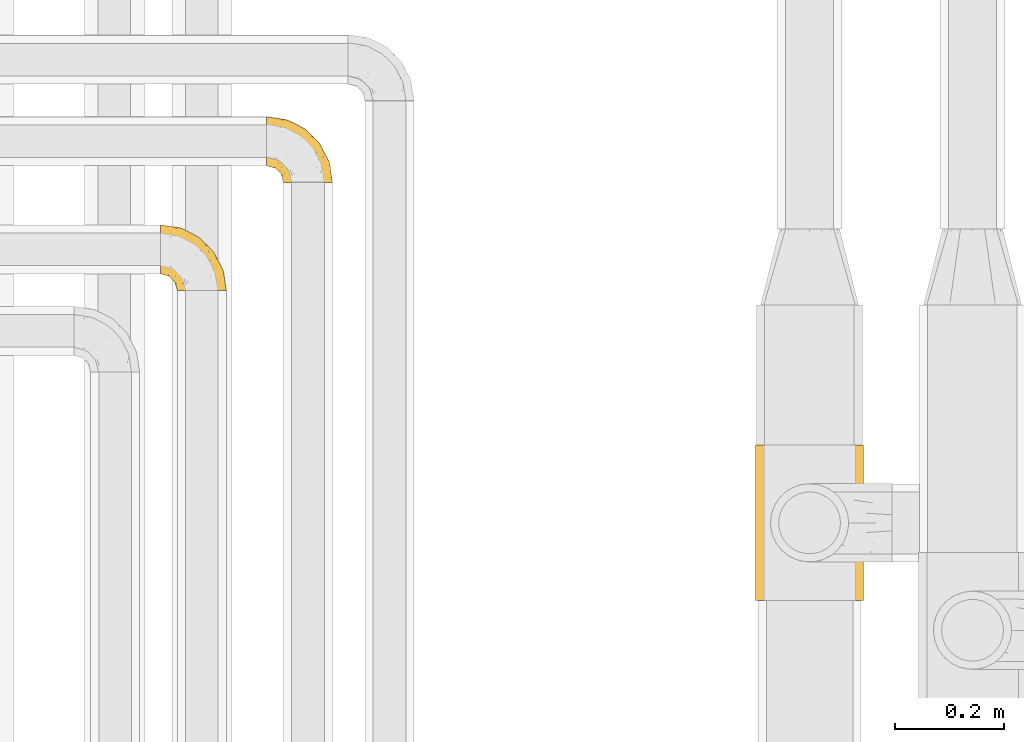
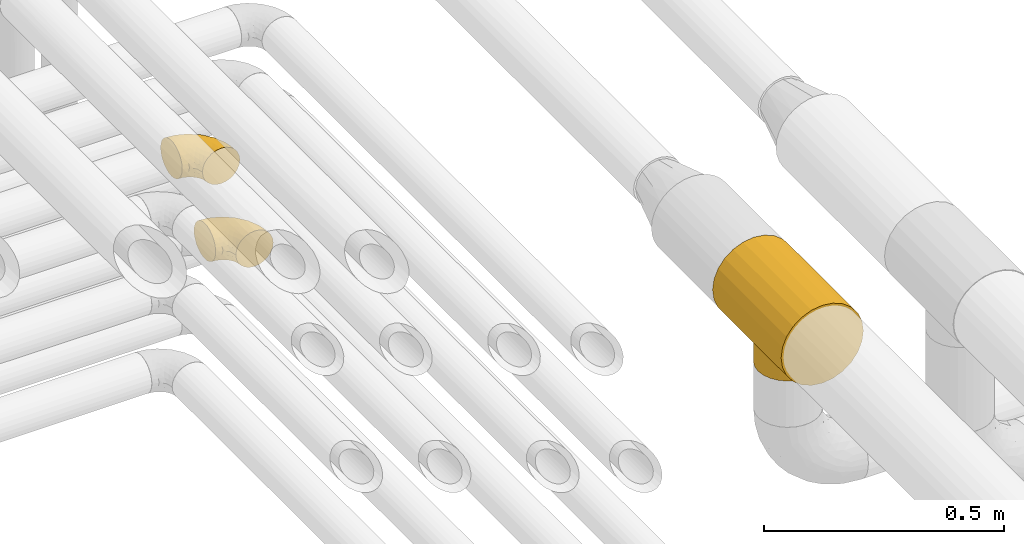
# One storey, part 339 of 827: 3 coverings.
"""IFC2X3 building model written with IfcOpenShell, lengths in millimetres."""

from ifc_helpers import new_model, entity, si_unit, converted_unit, derived_unit, direction, frame, origin, place, context, subcontext, project, spatial, faceted_brep, element, save


model = new_model("IFC2X3")

# Units and contexts
model_context = context("Model", 3, precision=0.01, world=origin(), true_north=direction((6.12303176911189e-17, 1.0)))
body_context = subcontext(model_context, "Body", "Model", "MODEL_VIEW")
ifc_project = project(units=[si_unit("LENGTHUNIT", "METRE", prefix="MILLI"), si_unit("AREAUNIT", "SQUARE_METRE"), si_unit("VOLUMEUNIT", "CUBIC_METRE"), converted_unit("PLANEANGLEUNIT", "DEGREE", entity("IfcRatioMeasure", 0.0174532925199433), si_unit("PLANEANGLEUNIT", "RADIAN"), dimensions=[0, 0, 0, 0, 0, 0, 0]), si_unit("MASSUNIT", "GRAM", prefix="KILO"), derived_unit("MASSDENSITYUNIT", [(si_unit("MASSUNIT", "GRAM", prefix="KILO"), 1), (si_unit("LENGTHUNIT", "METRE"), -3)]), derived_unit("MOMENTOFINERTIAUNIT", [(si_unit("LENGTHUNIT", "METRE"), 4)]), si_unit("TIMEUNIT", "SECOND"), si_unit("FREQUENCYUNIT", "HERTZ"), si_unit("THERMODYNAMICTEMPERATUREUNIT", "DEGREE_CELSIUS"), derived_unit("THERMALTRANSMITTANCEUNIT", [(si_unit("MASSUNIT", "GRAM", prefix="KILO"), 1), (si_unit("THERMODYNAMICTEMPERATUREUNIT", "KELVIN"), -1), (si_unit("TIMEUNIT", "SECOND"), -3)]), derived_unit("VOLUMETRICFLOWRATEUNIT", [(si_unit("LENGTHUNIT", "METRE"), 3), (si_unit("TIMEUNIT", "SECOND"), -1)]), derived_unit("MASSFLOWRATEUNIT", [(si_unit("MASSUNIT", "GRAM", prefix="KILO"), 1), (si_unit("TIMEUNIT", "SECOND"), -1)]), derived_unit("ROTATIONALFREQUENCYUNIT", [(si_unit("TIMEUNIT", "SECOND"), -1)]), si_unit("ELECTRICCURRENTUNIT", "AMPERE"), si_unit("ELECTRICVOLTAGEUNIT", "VOLT"), si_unit("POWERUNIT", "WATT"), si_unit("FORCEUNIT", "NEWTON", prefix="KILO"), si_unit("ILLUMINANCEUNIT", "LUX"), si_unit("LUMINOUSFLUXUNIT", "LUMEN"), si_unit("LUMINOUSINTENSITYUNIT", "CANDELA"), derived_unit("USERDEFINED", [(si_unit("MASSUNIT", "GRAM", prefix="KILO"), -1), (si_unit("LENGTHUNIT", "METRE"), -2), (si_unit("TIMEUNIT", "SECOND"), 3), (si_unit("LUMINOUSFLUXUNIT", "LUMEN"), 1)]), derived_unit("LINEARVELOCITYUNIT", [(si_unit("LENGTHUNIT", "METRE"), 1), (si_unit("TIMEUNIT", "SECOND"), -1)]), si_unit("PRESSUREUNIT", "PASCAL"), derived_unit("USERDEFINED", [(si_unit("LENGTHUNIT", "METRE"), -2), (si_unit("MASSUNIT", "GRAM", prefix="KILO"), 1), (si_unit("TIMEUNIT", "SECOND"), -2)]), derived_unit("LINEARFORCEUNIT", [(si_unit("MASSUNIT", "GRAM", prefix="KILO"), 1), (si_unit("LENGTHUNIT", "METRE"), 1), (si_unit("TIMEUNIT", "SECOND"), -2), (si_unit("LENGTHUNIT", "METRE"), -1)]), derived_unit("PLANARFORCEUNIT", [(si_unit("MASSUNIT", "GRAM", prefix="KILO"), 1), (si_unit("LENGTHUNIT", "METRE"), 1), (si_unit("TIMEUNIT", "SECOND"), -2), (si_unit("LENGTHUNIT", "METRE"), -2)])], contexts=[model_context])

# Site, building, storey
site_placement = place(None, origin())
site = spatial("IfcSite", under=ifc_project, at=site_placement, CompositionType="ELEMENT")
building_placement = place(site_placement, origin())
building = spatial("IfcBuilding", under=site, at=building_placement, CompositionType="ELEMENT")
storey_placement = place(building_placement, frame((0.0, 0.0, 28200.0)))
storey = spatial("IfcBuildingStorey", under=building, at=storey_placement, Name="08", CompositionType="ELEMENT", Elevation=28200.0)

# Coverings
covering_1_placement = place(storey_placement, frame((37647.55, 14143.62, 2769.91)))
element("IfcCovering", 1, at=covering_1_placement, inside=storey, Name=":ADSK_", ObjectType=":ADSK_", PredefinedType="INSULATION", context=body_context, shape_type="Brep", body=[
    faceted_brep([(4.97, 0.0, 104.34), (14.88, 0.0, 80.42), (30.64, 0.0, 59.89), (51.17, 0.0, 44.13), (63.13, 0.0, 39.18), (75.08, 0.0, 34.23), (87.91, 0.0, 32.54), (100.75, 0.0, 30.85), (113.58, 0.0, 32.54), (126.41, 0.0, 34.23), (138.36, 0.0, 39.18), (150.32, 0.0, 44.13), (170.85, 0.0, 59.89), (186.61, 0.0, 80.42), (196.52, 0.0, 104.34), (199.9, 0.0, 130.0), (196.52, 0.0, 155.66), (186.61, 0.0, 179.57), (170.85, 0.0, 200.11), (150.32, 0.0, 215.86), (126.41, 0.0, 225.77), (100.75, 0.0, 229.15), (75.08, 0.0, 225.77), (51.17, 0.0, 215.86), (30.64, 0.0, 200.11), (14.88, 0.0, 179.57), (4.97, 0.0, 155.66), (1.6, 0.0, 130.0), (199.9, 286.0, 130.01), (196.52, 286.0, 104.34), (186.61, 286.0, 80.43), (170.85, 286.0, 59.9), (150.32, 286.0, 44.14), (138.36, 286.0, 39.19), (126.41, 286.0, 34.23), (113.58, 286.0, 32.54), (100.75, 286.0, 30.86), (87.91, 286.0, 32.54), (75.08, 286.0, 34.23), (63.13, 286.0, 39.19), (51.17, 286.0, 44.14), (30.64, 286.0, 59.9), (14.88, 286.0, 80.43), (4.97, 286.0, 104.34), (1.6, 286.0, 130.01), (4.97, 286.0, 155.67), (14.88, 286.0, 179.58), (30.64, 286.0, 200.11), (51.17, 286.0, 215.87), (75.08, 286.0, 225.78), (100.75, 286.0, 229.16), (126.41, 286.0, 225.78), (150.32, 286.0, 215.87), (170.85, 286.0, 200.11), (186.61, 286.0, 179.58), (196.52, 286.0, 155.67), (100.75, 215.15, 30.85), (100.75, 70.85, 30.85), (126.23, 210.5, 34.19), (113.8, 213.96, 31.72), (147.57, 197.89, 42.61), (137.58, 205.04, 37.95), (113.8, 72.05, 31.71), (126.23, 75.51, 34.18), (147.57, 88.12, 42.61), (137.58, 80.97, 37.95), (156.09, 96.71, 47.73), (156.09, 189.3, 47.73), (163.04, 179.4, 52.87), (168.32, 168.28, 57.45), (171.71, 156.03, 60.76), (172.9, 143.0, 61.99), (163.04, 106.61, 52.87), (168.32, 117.73, 57.45), (171.71, 129.98, 60.76), (29.78, 156.03, 60.76), (28.6, 143.0, 61.99), (38.45, 179.4, 52.87), (45.4, 189.3, 47.73), (87.69, 213.96, 31.72), (33.17, 168.28, 57.45), (63.91, 80.97, 37.95), (29.78, 129.98, 60.76), (33.17, 117.73, 57.45), (87.69, 72.05, 31.71), (38.45, 106.61, 52.87), (53.92, 197.89, 42.61), (63.91, 205.04, 37.95), (75.26, 210.5, 34.19), (45.4, 96.71, 47.73), (53.92, 88.12, 42.61), (75.26, 75.51, 34.18), (172.9, 143.01, 0.0), (170.44, 124.33, 0.0), (163.23, 106.93, 0.0), (151.76, 91.99, 0.0), (136.82, 80.52, 0.0), (119.42, 73.31, 0.0), (100.75, 70.86, 0.0), (82.07, 73.31, 0.0), (64.67, 80.52, 0.0), (49.73, 91.99, 0.0), (38.26, 106.93, 0.0), (31.05, 124.33, 0.0), (28.6, 143.01, 0.0), (31.05, 161.68, 0.0), (38.26, 179.08, 0.0), (49.73, 194.02, 0.0), (64.67, 205.49, 0.0), (82.07, 212.7, 0.0), (100.75, 215.16, 0.0), (119.42, 212.7, 0.0), (136.82, 205.49, 0.0), (151.76, 194.02, 0.0), (163.23, 179.08, 0.0), (170.44, 161.68, 0.0)], [[[0, 1, 2, 3, 4, 5, 6, 7, 8, 9, 10, 11, 12, 13, 14, 15, 16, 17, 18, 19, 20, 21, 22, 23, 24, 25, 26, 27]], [[28, 29, 30, 31, 32, 33, 34, 35, 36, 37, 38, 39, 40, 41, 42, 43, 44, 45, 46, 47, 48, 49, 50, 51, 52, 53, 54, 55]], [[36, 35, 56]], [[57, 8, 7]], [[34, 58, 59]], [[59, 35, 34]], [[32, 60, 33]], [[61, 33, 60]], [[34, 61, 58]], [[57, 62, 8]], [[62, 63, 9]], [[64, 11, 10]], [[10, 9, 65]], [[11, 64, 66]], [[65, 9, 63]], [[67, 60, 32]], [[32, 68, 67]], [[68, 32, 31]], [[69, 68, 31]], [[31, 70, 69]], [[13, 30, 29, 14]], [[30, 71, 31]], [[31, 71, 70]], [[29, 28, 15, 14]], [[56, 35, 59]], [[72, 73, 12]], [[61, 34, 33]], [[72, 11, 66]], [[11, 72, 12]], [[73, 74, 12]], [[71, 13, 12]], [[62, 9, 8]], [[30, 13, 71]], [[71, 12, 74]], [[64, 10, 65]], [[16, 55, 54, 17]], [[17, 54, 53, 18]], [[28, 55, 16, 15]], [[19, 52, 51, 20]], [[20, 51, 50, 21]], [[18, 53, 52, 19]], [[22, 49, 48, 23]], [[23, 48, 47, 24]], [[50, 49, 22, 21]], [[25, 46, 45, 26]], [[26, 45, 44, 27]], [[24, 47, 46, 25]], [[0, 43, 42, 1]], [[41, 75, 76]], [[43, 0, 27, 44]], [[76, 42, 41]], [[77, 40, 78]], [[40, 77, 41]], [[79, 38, 37]], [[77, 80, 41]], [[81, 5, 4]], [[41, 80, 75]], [[42, 76, 1]], [[76, 2, 1]], [[82, 83, 2]], [[57, 6, 84]], [[3, 2, 85]], [[85, 2, 83]], [[86, 39, 87]], [[82, 2, 76]], [[39, 38, 87]], [[86, 40, 39]], [[38, 88, 87]], [[56, 79, 37]], [[88, 38, 79]], [[37, 36, 56]], [[6, 57, 7]], [[89, 90, 3]], [[90, 4, 3]], [[4, 90, 81]], [[89, 3, 85]], [[91, 84, 5]], [[84, 6, 5]], [[91, 5, 81]], [[86, 78, 40]], [[92, 93, 94, 95, 96, 97, 98, 99, 100, 101, 102, 103, 104, 105, 106, 107, 108, 109, 110, 111, 112, 113, 114, 115]], [[62, 57, 98]], [[62, 98, 97]], [[63, 97, 96]], [[63, 62, 97]], [[64, 65, 96]], [[63, 96, 65]], [[96, 95, 64]], [[66, 95, 94]], [[73, 94, 93]], [[74, 93, 92]], [[66, 94, 72]], [[93, 74, 73]], [[73, 72, 94]], [[74, 92, 71]], [[95, 66, 64]], [[70, 92, 115]], [[115, 114, 69]], [[67, 114, 113]], [[67, 68, 114]], [[71, 92, 70]], [[70, 115, 69]], [[114, 68, 69]], [[60, 113, 112]], [[58, 112, 111]], [[59, 111, 110]], [[61, 60, 112]], [[59, 58, 111]], [[56, 59, 110]], [[61, 112, 58]], [[113, 60, 67]], [[79, 56, 110]], [[79, 110, 109]], [[88, 109, 108]], [[88, 79, 109]], [[86, 87, 108]], [[88, 108, 87]], [[108, 107, 86]], [[78, 107, 106]], [[80, 106, 105]], [[75, 105, 104]], [[78, 106, 77]], [[105, 75, 80]], [[80, 77, 106]], [[75, 104, 76]], [[107, 78, 86]], [[82, 104, 103]], [[103, 102, 83]], [[89, 102, 101]], [[89, 85, 102]], [[76, 104, 82]], [[82, 103, 83]], [[102, 85, 83]], [[90, 101, 100]], [[91, 100, 99]], [[84, 99, 98]], [[81, 90, 100]], [[84, 91, 99]], [[57, 84, 98]], [[81, 100, 91]], [[101, 90, 89]]]),
])
covering_2_placement = place(storey_placement, frame((36552.05, 14712.41, 3353.25)))
element("IfcCovering", 2, at=covering_2_placement, inside=storey, Name=":ADSK_", ObjectType=":ADSK_", PredefinedType="INSULATION", context=body_context, shape_type="Brep", body=[
    faceted_brep([(1.6, 87.65, 90.76), (1.6, 97.19, 87.42), (1.6, 105.75, 82.04), (1.6, 112.9, 74.89), (1.6, 118.28, 66.33), (1.6, 121.61, 56.79), (1.6, 122.75, 46.75), (1.6, 121.61, 36.69), (1.6, 118.27, 27.15), (1.6, 112.89, 18.59), (1.6, 105.74, 11.44), (1.6, 97.18, 6.06), (1.6, 87.64, 2.73), (1.6, 77.6, 1.6), (1.6, 67.54, 2.73), (1.6, 58.0, 6.07), (1.6, 49.44, 11.45), (1.6, 42.29, 18.6), (1.6, 36.91, 27.16), (1.6, 33.58, 36.7), (1.6, 32.45, 46.75), (1.6, 33.58, 56.8), (1.6, 36.92, 66.34), (1.6, 42.3, 74.9), (1.6, 49.45, 82.05), (1.6, 58.01, 87.43), (1.6, 67.55, 90.76), (1.6, 77.6, 91.9), (33.98, 1.6, 35.06), (38.49, 1.6, 24.17), (45.67, 1.6, 14.82), (55.02, 1.6, 7.64), (65.91, 1.6, 3.13), (77.6, 1.6, 1.6), (89.28, 1.6, 3.13), (100.17, 1.6, 7.64), (109.52, 1.6, 14.82), (116.7, 1.6, 24.17), (121.21, 1.6, 35.06), (122.75, 1.6, 46.75), (121.21, 1.6, 58.43), (116.7, 1.6, 69.32), (109.52, 1.6, 78.67), (100.17, 1.6, 85.85), (89.28, 1.6, 90.36), (77.6, 1.6, 91.9), (65.91, 1.6, 90.36), (55.02, 1.6, 85.85), (45.67, 1.6, 78.67), (38.49, 1.6, 69.32), (33.98, 1.6, 58.43), (32.45, 1.6, 46.75), (72.81, 99.61, 46.75), (77.17, 95.26, 55.2), (86.21, 86.21, 46.75), (116.82, 39.03, 46.75), (118.49, 30.75, 54.53), (119.23, 23.8, 46.75), (105.14, 60.8, 59.63), (85.37, 85.37, 62.07), (89.33, 73.64, 71.86), (116.14, 31.01, 62.65), (105.06, 49.14, 71.33), (112.15, 23.88, 72.93), (22.95, 82.74, 91.2), (89.91, 43.48, 86.31), (103.39, 29.47, 80.89), (93.6, 56.38, 79.49), (51.41, 72.18, 90.68), (67.71, 72.24, 86.84), (43.53, 87.6, 87.38), (30.91, 107.24, 76.87), (23.58, 101.1, 83.73), (50.07, 95.16, 81.03), (30.68, 71.81, 91.9), (43.01, 63.57, 91.9), (55.34, 55.34, 91.9), (83.48, 23.66, 91.03), (94.96, 20.55, 87.58), (57.29, 107.97, 56.52), (39.03, 116.82, 46.75), (30.66, 117.03, 60.4), (71.81, 30.68, 91.9), (73.63, 21.51, 91.9), (75.46, 12.33, 91.9), (51.57, 106.17, 67.87), (73.13, 52.37, 90.35), (23.16, 114.51, 69.57), (23.8, 119.23, 46.75), (75.6, 78.37, 79.91), (12.33, 75.46, 91.9), (21.51, 73.63, 91.9), (50.46, 101.51, 74.99), (99.61, 72.81, 46.75), (63.57, 43.01, 91.9), (21.26, 92.6, 88.53), (69.54, 91.86, 72.65), (108.21, 55.92, 46.75), (68.42, 99.01, 62.97), (55.92, 108.21, 46.75), (19.36, 32.05, 66.2), (15.76, 30.22, 56.6), (26.13, 23.37, 59.89), (62.78, 28.43, 90.95), (63.65, 16.44, 90.22), (24.34, 37.1, 76.64), (28.46, 28.88, 71.58), (33.53, 33.93, 79.99), (39.46, 50.17, 89.54), (51.05, 40.57, 89.97), (10.94, 47.62, 81.32), (14.55, 39.9, 74.56), (22.21, 47.92, 84.15), (57.05, 34.27, 90.37), (54.0, 24.65, 87.82), (29.19, 62.6, 90.98), (18.85, 66.18, 90.96), (52.84, 11.74, 85.14), (31.47, 13.89, 58.11), (28.31, 17.02, 46.75), (43.0, 15.86, 78.39), (16.9, 57.71, 88.22), (35.98, 9.11, 66.06), (33.91, 18.55, 68.6), (9.97, 34.74, 63.78), (25.93, 54.95, 88.42), (35.61, 57.35, 90.61), (47.45, 22.03, 83.8), (38.26, 24.8, 77.98), (11.7, 69.07, 91.22), (30.13, 42.31, 83.46), (12.12, 29.63, 46.75), (17.02, 28.31, 46.75), (44.39, 30.23, 84.66), (39.83, 40.13, 86.33), (22.67, 22.67, 46.75), (29.63, 12.12, 46.75), (43.0, 15.86, 15.1), (47.45, 22.03, 9.69), (38.26, 24.8, 15.52), (44.38, 30.23, 8.83), (31.47, 13.88, 35.39), (10.93, 47.61, 12.18), (21.51, 73.63, 1.6), (18.84, 66.17, 2.53), (11.7, 69.07, 2.27), (15.76, 30.22, 36.9), (19.36, 32.04, 27.31), (26.14, 23.36, 33.62), (25.94, 54.93, 5.07), (22.21, 47.91, 9.36), (16.9, 57.69, 5.27), (35.98, 9.1, 27.43), (73.63, 21.51, 1.6), (75.46, 12.33, 1.6), (30.12, 42.29, 10.05), (24.33, 37.09, 16.87), (52.84, 11.74, 8.35), (63.65, 16.44, 3.27), (71.81, 30.68, 1.6), (28.45, 28.86, 21.94), (9.97, 34.74, 29.72), (43.01, 63.57, 1.6), (55.34, 55.34, 1.6), (39.46, 50.17, 3.96), (12.33, 75.46, 1.6), (14.54, 39.89, 18.95), (62.78, 28.43, 2.54), (57.05, 34.27, 3.12), (63.57, 43.01, 1.6), (29.2, 62.59, 2.51), (51.05, 40.57, 3.52), (39.81, 40.13, 7.17), (30.68, 71.81, 1.6), (33.52, 33.92, 13.52), (35.61, 57.34, 2.88), (54.0, 24.65, 5.67), (33.91, 18.54, 24.89), (103.39, 29.47, 12.6), (89.91, 43.48, 7.18), (93.6, 56.4, 14.0), (105.05, 49.17, 22.16), (89.27, 73.69, 21.61), (73.13, 52.37, 3.14), (67.67, 72.26, 6.65), (69.49, 91.88, 20.82), (85.36, 85.36, 31.41), (94.96, 20.55, 5.91), (83.48, 23.66, 2.46), (105.14, 60.8, 33.87), (116.13, 31.02, 30.84), (118.49, 30.75, 38.96), (112.15, 23.9, 20.56), (51.41, 72.17, 2.81), (43.51, 87.59, 6.1), (22.95, 82.74, 2.29), (30.66, 117.03, 33.08), (30.91, 107.23, 16.61), (57.3, 107.97, 36.96), (23.58, 101.08, 9.75), (51.56, 106.17, 25.61), (68.41, 99.01, 30.5), (23.16, 114.5, 23.91), (50.07, 95.15, 12.45), (50.45, 101.5, 18.49), (21.25, 92.59, 4.96), (75.56, 78.38, 13.56), (77.16, 95.27, 38.28)], [[[0, 1, 2, 3, 4, 5, 6, 7, 8, 9, 10, 11, 12, 13, 14, 15, 16, 17, 18, 19, 20, 21, 22, 23, 24, 25, 26, 27]], [[28, 29, 30, 31, 32, 33, 34, 35, 36, 37, 38, 39, 40, 41, 42, 43, 44, 45, 46, 47, 48, 49, 50, 51]], [[52, 53, 54]], [[55, 56, 57]], [[58, 59, 60]], [[61, 62, 63]], [[27, 64, 0]], [[65, 66, 67]], [[41, 40, 61]], [[68, 69, 70]], [[66, 43, 42]], [[63, 42, 41]], [[71, 72, 73]], [[72, 2, 1]], [[68, 74, 75, 76]], [[45, 44, 77]], [[43, 78, 44]], [[79, 80, 81]], [[77, 82, 83, 84, 45]], [[79, 81, 85]], [[71, 2, 72]], [[65, 86, 77]], [[4, 81, 5]], [[66, 65, 78]], [[4, 3, 87]], [[81, 88, 5]], [[63, 66, 42]], [[68, 70, 64]], [[67, 60, 89]], [[71, 3, 2]], [[64, 27, 90, 91, 74]], [[92, 71, 73]], [[40, 57, 56]], [[59, 93, 54]], [[86, 76, 94, 82]], [[1, 0, 95]], [[58, 62, 61]], [[60, 96, 89]], [[85, 81, 87]], [[56, 97, 58]], [[65, 67, 69]], [[87, 81, 4]], [[67, 89, 69]], [[61, 63, 41]], [[95, 72, 1]], [[73, 72, 70]], [[69, 73, 70]], [[73, 89, 96]], [[3, 71, 87]], [[85, 87, 71]], [[58, 61, 56]], [[59, 58, 93]], [[76, 86, 68]], [[69, 89, 73]], [[68, 86, 69]], [[65, 69, 86]], [[68, 64, 74]], [[95, 64, 70]], [[98, 79, 85]], [[79, 52, 99, 80]], [[66, 62, 67]], [[62, 58, 60]], [[62, 60, 67]], [[59, 98, 96]], [[59, 96, 60]], [[96, 85, 92]], [[88, 81, 80]], [[88, 6, 5]], [[66, 63, 62]], [[64, 95, 0]], [[72, 95, 70]], [[77, 44, 78]], [[86, 82, 77]], [[40, 39, 57]], [[96, 98, 85]], [[40, 56, 61]], [[66, 78, 43]], [[77, 78, 65]], [[79, 98, 53]], [[96, 92, 73]], [[85, 71, 92]], [[97, 56, 55]], [[97, 93, 58]], [[53, 98, 59]], [[54, 53, 59]], [[79, 53, 52]], [[100, 101, 102]], [[46, 45, 84, 83]], [[103, 104, 82]], [[82, 104, 83]], [[105, 106, 107]], [[108, 109, 76]], [[110, 111, 112]], [[103, 113, 114]], [[115, 74, 116]], [[48, 47, 117]], [[118, 102, 119]], [[49, 48, 120]], [[74, 91, 116]], [[116, 121, 115]], [[49, 122, 50]], [[123, 106, 102]], [[124, 111, 22]], [[125, 126, 115]], [[23, 22, 111]], [[24, 110, 121]], [[120, 127, 128]], [[90, 26, 129]], [[27, 26, 90]], [[121, 125, 115]], [[24, 121, 25]], [[130, 105, 107]], [[129, 25, 116]], [[21, 20, 131]], [[120, 123, 122]], [[112, 105, 130]], [[50, 118, 51]], [[21, 124, 22]], [[101, 131, 132]], [[117, 120, 48]], [[24, 23, 110]], [[127, 114, 133]], [[75, 108, 76]], [[107, 134, 130]], [[133, 114, 113]], [[129, 116, 91]], [[25, 121, 116]], [[121, 112, 125]], [[75, 74, 115]], [[101, 135, 102]], [[131, 101, 21]], [[101, 100, 124]], [[128, 127, 133]], [[119, 136, 51, 118]], [[104, 47, 46]], [[83, 104, 46]], [[117, 104, 114]], [[101, 124, 21]], [[111, 124, 100]], [[102, 118, 123]], [[133, 134, 107]], [[111, 110, 23]], [[114, 104, 103]], [[94, 76, 109]], [[121, 110, 112]], [[122, 118, 50]], [[134, 109, 108]], [[133, 107, 128]], [[112, 108, 125]], [[126, 125, 108]], [[108, 75, 126]], [[75, 115, 126]], [[109, 134, 133]], [[130, 108, 112]], [[108, 130, 134]], [[105, 112, 111]], [[111, 100, 105]], [[106, 105, 100]], [[102, 106, 100]], [[128, 106, 123]], [[90, 129, 91]], [[25, 129, 26]], [[104, 117, 47]], [[117, 114, 127]], [[82, 94, 103]], [[113, 94, 109]], [[94, 113, 103]], [[133, 113, 109]], [[106, 128, 107]], [[123, 120, 128]], [[120, 122, 49]], [[118, 122, 123]], [[135, 101, 132]], [[135, 119, 102]], [[117, 127, 120]], [[30, 29, 137]], [[138, 139, 140]], [[51, 136, 119, 141]], [[142, 17, 16]], [[143, 144, 145]], [[146, 147, 148]], [[149, 150, 151]], [[152, 29, 28]], [[33, 32, 153, 154]], [[150, 155, 156]], [[157, 31, 30]], [[153, 158, 159]], [[29, 152, 137]], [[148, 141, 119]], [[156, 160, 147]], [[148, 135, 146]], [[137, 138, 157]], [[19, 161, 146]], [[162, 163, 164]], [[14, 13, 165]], [[153, 32, 158]], [[147, 161, 166]], [[18, 17, 166]], [[167, 168, 169]], [[166, 150, 156]], [[151, 150, 142]], [[151, 170, 149]], [[151, 16, 15]], [[171, 140, 172]], [[165, 143, 145]], [[173, 170, 144]], [[142, 166, 17]], [[19, 131, 20]], [[144, 170, 151]], [[18, 161, 19]], [[173, 144, 143]], [[140, 139, 174]], [[171, 164, 163]], [[164, 172, 155]], [[151, 15, 144]], [[145, 15, 14]], [[173, 162, 170]], [[149, 175, 164]], [[19, 146, 131]], [[132, 131, 146]], [[160, 148, 147]], [[159, 158, 167]], [[135, 132, 146]], [[158, 32, 31]], [[157, 158, 31]], [[167, 158, 176]], [[166, 161, 18]], [[146, 161, 147]], [[148, 177, 141]], [[171, 168, 140]], [[171, 163, 169]], [[151, 142, 16]], [[166, 142, 150]], [[152, 141, 177]], [[51, 141, 28]], [[138, 140, 176]], [[172, 140, 174]], [[175, 149, 170]], [[164, 150, 149]], [[170, 162, 175]], [[162, 164, 175]], [[155, 172, 174]], [[171, 172, 164]], [[155, 174, 156]], [[164, 155, 150]], [[160, 156, 174]], [[147, 166, 156]], [[139, 160, 174]], [[148, 160, 177]], [[15, 145, 144]], [[165, 145, 14]], [[137, 157, 30]], [[158, 157, 176]], [[168, 167, 176]], [[169, 159, 167]], [[140, 168, 176]], [[169, 168, 171]], [[137, 177, 139]], [[160, 139, 177]], [[141, 152, 28]], [[137, 152, 177]], [[148, 119, 135]], [[157, 138, 176]], [[139, 138, 137]], [[178, 179, 180]], [[181, 180, 182]], [[179, 183, 184]], [[185, 186, 182]], [[187, 188, 179]], [[188, 33, 154, 153, 159]], [[181, 189, 190]], [[35, 34, 187]], [[191, 38, 190]], [[192, 178, 181]], [[179, 184, 180]], [[192, 190, 37]], [[37, 190, 38]], [[36, 35, 178]], [[54, 93, 186]], [[35, 187, 178]], [[193, 194, 184]], [[195, 173, 143, 165, 13]], [[195, 193, 173]], [[193, 163, 162, 173]], [[13, 12, 195]], [[8, 7, 196]], [[9, 197, 10]], [[198, 80, 99, 52]], [[196, 7, 88]], [[197, 199, 10]], [[182, 189, 181]], [[200, 198, 201]], [[200, 196, 198]], [[9, 8, 202]], [[194, 199, 203]], [[192, 37, 36]], [[80, 196, 88]], [[183, 159, 169, 163]], [[188, 34, 33]], [[202, 200, 197]], [[185, 203, 204]], [[202, 8, 196]], [[10, 199, 11]], [[12, 11, 205]], [[38, 191, 57]], [[189, 97, 191]], [[203, 199, 197]], [[205, 199, 194]], [[204, 203, 197]], [[184, 203, 206]], [[200, 202, 196]], [[197, 9, 202]], [[207, 54, 186]], [[97, 55, 191]], [[194, 203, 184]], [[183, 163, 193]], [[184, 206, 180]], [[183, 193, 184]], [[205, 195, 12]], [[193, 195, 194]], [[80, 198, 196]], [[207, 186, 201]], [[182, 180, 206]], [[181, 178, 180]], [[185, 182, 206]], [[182, 186, 189]], [[203, 185, 206]], [[185, 200, 201]], [[7, 6, 88]], [[178, 192, 36]], [[190, 192, 181]], [[199, 205, 11]], [[195, 205, 194]], [[159, 183, 188]], [[179, 188, 183]], [[57, 191, 55]], [[57, 39, 38]], [[189, 191, 190]], [[188, 187, 34]], [[178, 187, 179]], [[186, 93, 189]], [[197, 200, 204]], [[185, 204, 200]], [[189, 93, 97]], [[207, 198, 52]], [[185, 201, 186]], [[198, 207, 201]], [[54, 207, 52]]]),
])
covering_3_placement = place(storey_placement, frame((36747.44, 14911.41, 2953.25)))
element("IfcCovering", 3, at=covering_3_placement, inside=storey, Name=":ADSK_", ObjectType=":ADSK_", PredefinedType="INSULATION", context=body_context, shape_type="Brep", body=[
    faceted_brep([(1.6, 87.65, 90.76), (1.6, 97.19, 87.42), (1.6, 105.75, 82.04), (1.6, 112.9, 74.89), (1.6, 118.28, 66.33), (1.6, 121.61, 56.79), (1.6, 122.75, 46.75), (1.6, 121.61, 36.69), (1.6, 118.27, 27.15), (1.6, 112.89, 18.59), (1.6, 105.74, 11.44), (1.6, 97.18, 6.06), (1.6, 87.64, 2.73), (1.6, 77.6, 1.6), (1.6, 67.54, 2.73), (1.6, 58.0, 6.07), (1.6, 49.44, 11.45), (1.6, 42.29, 18.6), (1.6, 36.91, 27.16), (1.6, 33.58, 36.7), (1.6, 32.45, 46.75), (1.6, 33.58, 56.8), (1.6, 36.92, 66.34), (1.6, 42.3, 74.9), (1.6, 49.45, 82.05), (1.6, 58.01, 87.43), (1.6, 67.55, 90.76), (1.6, 77.6, 91.9), (33.98, 1.6, 35.06), (38.49, 1.6, 24.17), (45.67, 1.6, 14.82), (55.02, 1.6, 7.64), (65.91, 1.6, 3.13), (77.6, 1.6, 1.6), (89.28, 1.6, 3.13), (100.17, 1.6, 7.64), (109.52, 1.6, 14.82), (116.7, 1.6, 24.17), (121.21, 1.6, 35.06), (122.75, 1.6, 46.75), (121.21, 1.6, 58.43), (116.7, 1.6, 69.32), (109.52, 1.6, 78.67), (100.17, 1.6, 85.85), (89.28, 1.6, 90.36), (77.6, 1.6, 91.9), (65.91, 1.6, 90.36), (55.02, 1.6, 85.85), (45.67, 1.6, 78.67), (38.49, 1.6, 69.32), (33.98, 1.6, 58.43), (32.45, 1.6, 46.75), (72.81, 99.61, 46.75), (77.17, 95.26, 55.2), (86.21, 86.21, 46.75), (116.82, 39.03, 46.75), (118.49, 30.75, 54.53), (119.23, 23.8, 46.75), (105.14, 60.8, 59.63), (85.37, 85.37, 62.07), (89.33, 73.64, 71.86), (116.14, 31.01, 62.65), (105.06, 49.14, 71.33), (112.15, 23.88, 72.93), (22.95, 82.74, 91.2), (89.91, 43.48, 86.31), (103.39, 29.47, 80.89), (93.6, 56.38, 79.49), (51.41, 72.18, 90.68), (67.71, 72.24, 86.84), (43.53, 87.6, 87.38), (30.91, 107.24, 76.87), (23.58, 101.1, 83.73), (50.07, 95.16, 81.03), (30.68, 71.81, 91.9), (43.01, 63.57, 91.9), (55.34, 55.34, 91.9), (83.48, 23.66, 91.03), (94.96, 20.55, 87.58), (57.29, 107.97, 56.52), (39.03, 116.82, 46.75), (30.66, 117.03, 60.4), (71.81, 30.68, 91.9), (73.63, 21.51, 91.9), (75.46, 12.33, 91.9), (51.57, 106.17, 67.87), (73.13, 52.37, 90.35), (23.16, 114.51, 69.57), (23.8, 119.23, 46.75), (75.6, 78.37, 79.91), (12.33, 75.46, 91.9), (21.51, 73.63, 91.9), (50.46, 101.51, 74.99), (99.61, 72.81, 46.75), (63.57, 43.01, 91.9), (21.26, 92.6, 88.53), (69.54, 91.86, 72.65), (108.21, 55.92, 46.75), (68.42, 99.01, 62.97), (55.92, 108.21, 46.75), (19.36, 32.05, 66.2), (15.76, 30.22, 56.6), (26.13, 23.37, 59.89), (62.78, 28.43, 90.95), (63.65, 16.44, 90.22), (24.34, 37.1, 76.64), (28.46, 28.88, 71.58), (33.53, 33.93, 79.99), (39.46, 50.17, 89.54), (51.05, 40.57, 89.97), (10.94, 47.62, 81.32), (14.55, 39.9, 74.56), (22.21, 47.92, 84.15), (57.05, 34.27, 90.37), (54.0, 24.65, 87.82), (29.19, 62.6, 90.98), (18.85, 66.18, 90.96), (52.84, 11.74, 85.14), (31.47, 13.89, 58.11), (28.31, 17.02, 46.75), (43.0, 15.86, 78.39), (16.9, 57.71, 88.22), (35.98, 9.11, 66.06), (33.91, 18.55, 68.6), (9.97, 34.74, 63.78), (25.93, 54.95, 88.42), (35.61, 57.35, 90.61), (47.45, 22.03, 83.8), (38.26, 24.8, 77.98), (11.7, 69.07, 91.22), (30.13, 42.31, 83.46), (12.12, 29.63, 46.75), (17.02, 28.31, 46.75), (44.39, 30.23, 84.66), (39.83, 40.13, 86.33), (22.67, 22.67, 46.75), (29.63, 12.12, 46.75), (43.0, 15.86, 15.1), (47.45, 22.03, 9.69), (38.26, 24.8, 15.52), (44.38, 30.23, 8.83), (31.47, 13.88, 35.39), (10.93, 47.61, 12.18), (21.51, 73.63, 1.6), (18.84, 66.17, 2.53), (11.7, 69.07, 2.27), (15.76, 30.22, 36.9), (19.36, 32.04, 27.31), (26.14, 23.36, 33.62), (25.94, 54.93, 5.07), (22.21, 47.91, 9.36), (16.9, 57.69, 5.27), (35.98, 9.1, 27.43), (73.63, 21.51, 1.6), (75.46, 12.33, 1.6), (30.12, 42.29, 10.05), (24.33, 37.09, 16.87), (52.84, 11.74, 8.35), (63.65, 16.44, 3.27), (71.81, 30.68, 1.6), (28.45, 28.86, 21.94), (9.97, 34.74, 29.72), (43.01, 63.57, 1.6), (55.34, 55.34, 1.6), (39.46, 50.17, 3.96), (12.33, 75.46, 1.6), (14.54, 39.89, 18.95), (62.78, 28.43, 2.54), (57.05, 34.27, 3.12), (63.57, 43.01, 1.6), (29.2, 62.59, 2.51), (51.05, 40.57, 3.52), (39.81, 40.13, 7.17), (30.68, 71.81, 1.6), (33.52, 33.92, 13.52), (35.61, 57.34, 2.88), (54.0, 24.65, 5.67), (33.91, 18.54, 24.89), (103.39, 29.47, 12.6), (89.91, 43.48, 7.18), (93.6, 56.4, 14.0), (105.05, 49.17, 22.16), (89.27, 73.69, 21.61), (73.13, 52.37, 3.14), (67.67, 72.26, 6.65), (69.49, 91.88, 20.82), (85.36, 85.36, 31.41), (94.96, 20.55, 5.91), (83.48, 23.66, 2.46), (105.14, 60.8, 33.87), (116.13, 31.02, 30.84), (118.49, 30.75, 38.96), (112.15, 23.9, 20.56), (51.41, 72.17, 2.81), (43.51, 87.59, 6.1), (22.95, 82.74, 2.29), (30.66, 117.03, 33.08), (30.91, 107.23, 16.61), (57.3, 107.97, 36.96), (23.58, 101.08, 9.75), (51.56, 106.17, 25.61), (68.41, 99.01, 30.5), (23.16, 114.5, 23.91), (50.07, 95.15, 12.45), (50.45, 101.5, 18.49), (21.25, 92.59, 4.96), (75.56, 78.38, 13.56), (77.16, 95.27, 38.28)], [[[0, 1, 2, 3, 4, 5, 6, 7, 8, 9, 10, 11, 12, 13, 14, 15, 16, 17, 18, 19, 20, 21, 22, 23, 24, 25, 26, 27]], [[28, 29, 30, 31, 32, 33, 34, 35, 36, 37, 38, 39, 40, 41, 42, 43, 44, 45, 46, 47, 48, 49, 50, 51]], [[52, 53, 54]], [[55, 56, 57]], [[58, 59, 60]], [[61, 62, 63]], [[27, 64, 0]], [[65, 66, 67]], [[41, 40, 61]], [[68, 69, 70]], [[66, 43, 42]], [[63, 42, 41]], [[71, 72, 73]], [[72, 2, 1]], [[68, 74, 75, 76]], [[45, 44, 77]], [[43, 78, 44]], [[79, 80, 81]], [[77, 82, 83, 84, 45]], [[79, 81, 85]], [[71, 2, 72]], [[65, 86, 77]], [[4, 81, 5]], [[66, 65, 78]], [[4, 3, 87]], [[81, 88, 5]], [[63, 66, 42]], [[68, 70, 64]], [[67, 60, 89]], [[71, 3, 2]], [[64, 27, 90, 91, 74]], [[92, 71, 73]], [[40, 57, 56]], [[59, 93, 54]], [[86, 76, 94, 82]], [[1, 0, 95]], [[58, 62, 61]], [[60, 96, 89]], [[85, 81, 87]], [[56, 97, 58]], [[65, 67, 69]], [[87, 81, 4]], [[67, 89, 69]], [[61, 63, 41]], [[95, 72, 1]], [[73, 72, 70]], [[69, 73, 70]], [[73, 89, 96]], [[3, 71, 87]], [[85, 87, 71]], [[58, 61, 56]], [[59, 58, 93]], [[76, 86, 68]], [[69, 89, 73]], [[68, 86, 69]], [[65, 69, 86]], [[68, 64, 74]], [[95, 64, 70]], [[98, 79, 85]], [[79, 52, 99, 80]], [[66, 62, 67]], [[62, 58, 60]], [[62, 60, 67]], [[59, 98, 96]], [[59, 96, 60]], [[96, 85, 92]], [[88, 81, 80]], [[88, 6, 5]], [[66, 63, 62]], [[64, 95, 0]], [[72, 95, 70]], [[77, 44, 78]], [[86, 82, 77]], [[40, 39, 57]], [[96, 98, 85]], [[40, 56, 61]], [[66, 78, 43]], [[77, 78, 65]], [[79, 98, 53]], [[96, 92, 73]], [[85, 71, 92]], [[97, 56, 55]], [[97, 93, 58]], [[53, 98, 59]], [[54, 53, 59]], [[79, 53, 52]], [[100, 101, 102]], [[46, 45, 84, 83]], [[103, 104, 82]], [[82, 104, 83]], [[105, 106, 107]], [[108, 109, 76]], [[110, 111, 112]], [[103, 113, 114]], [[115, 74, 116]], [[48, 47, 117]], [[118, 102, 119]], [[49, 48, 120]], [[74, 91, 116]], [[116, 121, 115]], [[49, 122, 50]], [[123, 106, 102]], [[124, 111, 22]], [[125, 126, 115]], [[23, 22, 111]], [[24, 110, 121]], [[120, 127, 128]], [[90, 26, 129]], [[27, 26, 90]], [[121, 125, 115]], [[24, 121, 25]], [[130, 105, 107]], [[129, 25, 116]], [[21, 20, 131]], [[120, 123, 122]], [[112, 105, 130]], [[50, 118, 51]], [[21, 124, 22]], [[101, 131, 132]], [[117, 120, 48]], [[24, 23, 110]], [[127, 114, 133]], [[75, 108, 76]], [[107, 134, 130]], [[133, 114, 113]], [[129, 116, 91]], [[25, 121, 116]], [[121, 112, 125]], [[75, 74, 115]], [[101, 135, 102]], [[131, 101, 21]], [[101, 100, 124]], [[128, 127, 133]], [[119, 136, 51, 118]], [[104, 47, 46]], [[83, 104, 46]], [[117, 104, 114]], [[101, 124, 21]], [[111, 124, 100]], [[102, 118, 123]], [[133, 134, 107]], [[111, 110, 23]], [[114, 104, 103]], [[94, 76, 109]], [[121, 110, 112]], [[122, 118, 50]], [[134, 109, 108]], [[133, 107, 128]], [[112, 108, 125]], [[126, 125, 108]], [[108, 75, 126]], [[75, 115, 126]], [[109, 134, 133]], [[130, 108, 112]], [[108, 130, 134]], [[105, 112, 111]], [[111, 100, 105]], [[106, 105, 100]], [[102, 106, 100]], [[128, 106, 123]], [[90, 129, 91]], [[25, 129, 26]], [[104, 117, 47]], [[117, 114, 127]], [[82, 94, 103]], [[113, 94, 109]], [[94, 113, 103]], [[133, 113, 109]], [[106, 128, 107]], [[123, 120, 128]], [[120, 122, 49]], [[118, 122, 123]], [[135, 101, 132]], [[135, 119, 102]], [[117, 127, 120]], [[30, 29, 137]], [[138, 139, 140]], [[51, 136, 119, 141]], [[142, 17, 16]], [[143, 144, 145]], [[146, 147, 148]], [[149, 150, 151]], [[152, 29, 28]], [[33, 32, 153, 154]], [[150, 155, 156]], [[157, 31, 30]], [[153, 158, 159]], [[29, 152, 137]], [[148, 141, 119]], [[156, 160, 147]], [[148, 135, 146]], [[137, 138, 157]], [[19, 161, 146]], [[162, 163, 164]], [[14, 13, 165]], [[153, 32, 158]], [[147, 161, 166]], [[18, 17, 166]], [[167, 168, 169]], [[166, 150, 156]], [[151, 150, 142]], [[151, 170, 149]], [[151, 16, 15]], [[171, 140, 172]], [[165, 143, 145]], [[173, 170, 144]], [[142, 166, 17]], [[19, 131, 20]], [[144, 170, 151]], [[18, 161, 19]], [[173, 144, 143]], [[140, 139, 174]], [[171, 164, 163]], [[164, 172, 155]], [[151, 15, 144]], [[145, 15, 14]], [[173, 162, 170]], [[149, 175, 164]], [[19, 146, 131]], [[132, 131, 146]], [[160, 148, 147]], [[159, 158, 167]], [[135, 132, 146]], [[158, 32, 31]], [[157, 158, 31]], [[167, 158, 176]], [[166, 161, 18]], [[146, 161, 147]], [[148, 177, 141]], [[171, 168, 140]], [[171, 163, 169]], [[151, 142, 16]], [[166, 142, 150]], [[152, 141, 177]], [[51, 141, 28]], [[138, 140, 176]], [[172, 140, 174]], [[175, 149, 170]], [[164, 150, 149]], [[170, 162, 175]], [[162, 164, 175]], [[155, 172, 174]], [[171, 172, 164]], [[155, 174, 156]], [[164, 155, 150]], [[160, 156, 174]], [[147, 166, 156]], [[139, 160, 174]], [[148, 160, 177]], [[15, 145, 144]], [[165, 145, 14]], [[137, 157, 30]], [[158, 157, 176]], [[168, 167, 176]], [[169, 159, 167]], [[140, 168, 176]], [[169, 168, 171]], [[137, 177, 139]], [[160, 139, 177]], [[141, 152, 28]], [[137, 152, 177]], [[148, 119, 135]], [[157, 138, 176]], [[139, 138, 137]], [[178, 179, 180]], [[181, 180, 182]], [[179, 183, 184]], [[185, 186, 182]], [[187, 188, 179]], [[188, 33, 154, 153, 159]], [[181, 189, 190]], [[35, 34, 187]], [[191, 38, 190]], [[192, 178, 181]], [[179, 184, 180]], [[192, 190, 37]], [[37, 190, 38]], [[36, 35, 178]], [[54, 93, 186]], [[35, 187, 178]], [[193, 194, 184]], [[195, 173, 143, 165, 13]], [[195, 193, 173]], [[193, 163, 162, 173]], [[13, 12, 195]], [[8, 7, 196]], [[9, 197, 10]], [[198, 80, 99, 52]], [[196, 7, 88]], [[197, 199, 10]], [[182, 189, 181]], [[200, 198, 201]], [[200, 196, 198]], [[9, 8, 202]], [[194, 199, 203]], [[192, 37, 36]], [[80, 196, 88]], [[183, 159, 169, 163]], [[188, 34, 33]], [[202, 200, 197]], [[185, 203, 204]], [[202, 8, 196]], [[10, 199, 11]], [[12, 11, 205]], [[38, 191, 57]], [[189, 97, 191]], [[203, 199, 197]], [[205, 199, 194]], [[204, 203, 197]], [[184, 203, 206]], [[200, 202, 196]], [[197, 9, 202]], [[207, 54, 186]], [[97, 55, 191]], [[194, 203, 184]], [[183, 163, 193]], [[184, 206, 180]], [[183, 193, 184]], [[205, 195, 12]], [[193, 195, 194]], [[80, 198, 196]], [[207, 186, 201]], [[182, 180, 206]], [[181, 178, 180]], [[185, 182, 206]], [[182, 186, 189]], [[203, 185, 206]], [[185, 200, 201]], [[7, 6, 88]], [[178, 192, 36]], [[190, 192, 181]], [[199, 205, 11]], [[195, 205, 194]], [[159, 183, 188]], [[179, 188, 183]], [[57, 191, 55]], [[57, 39, 38]], [[189, 191, 190]], [[188, 187, 34]], [[178, 187, 179]], [[186, 93, 189]], [[197, 200, 204]], [[185, 204, 200]], [[189, 93, 97]], [[207, 198, 52]], [[185, 201, 186]], [[198, 207, 201]], [[54, 207, 52]]]),
])

save(model, "model.ifc")
